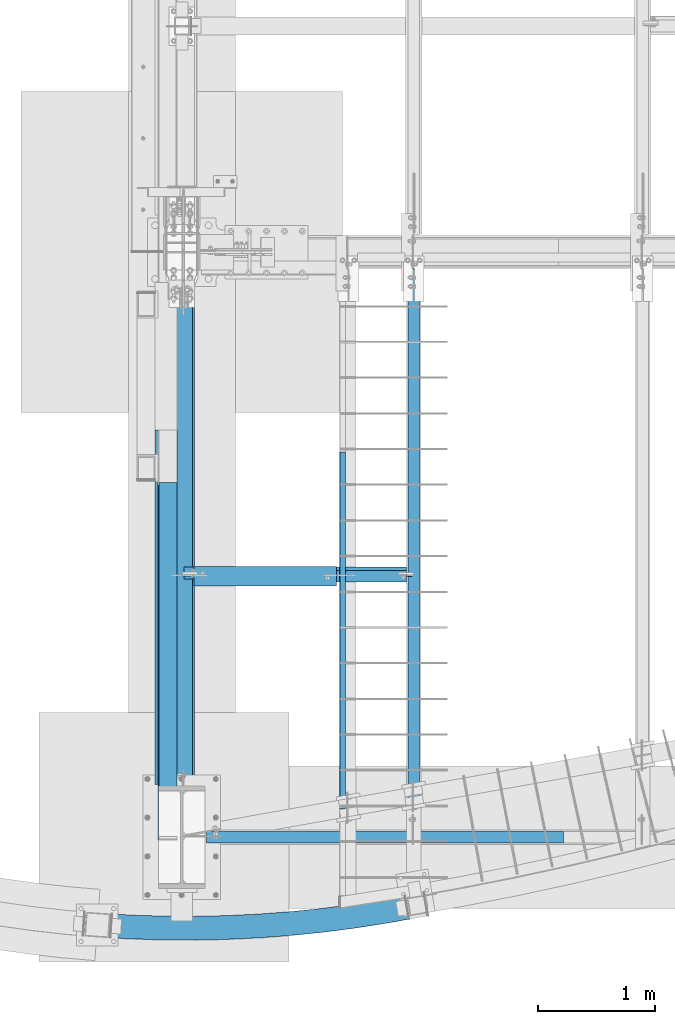
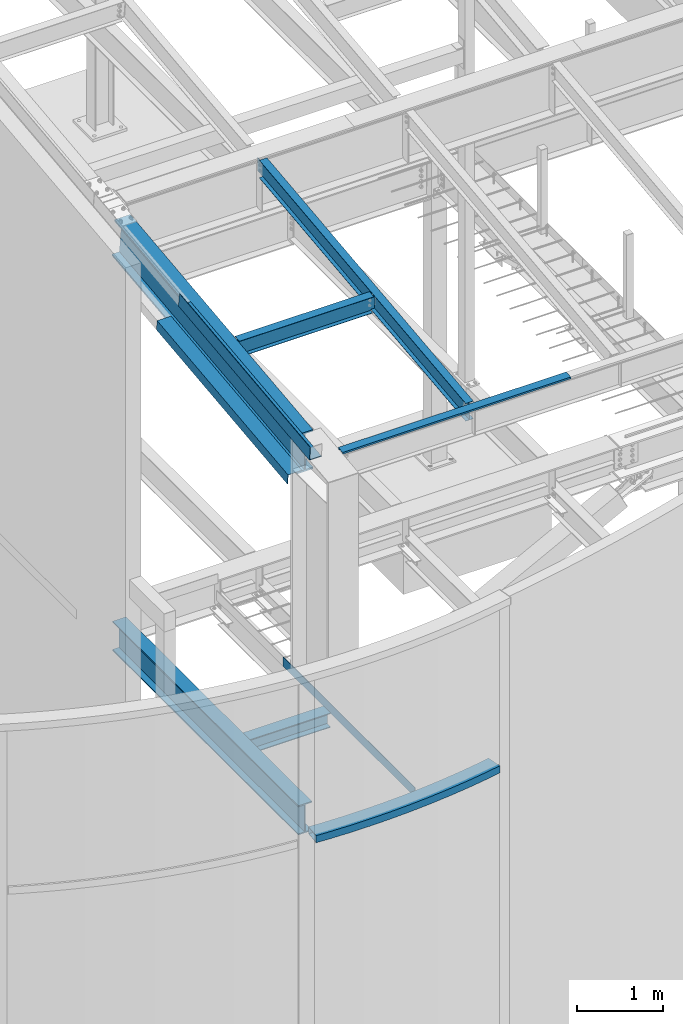
# One storey, part 701 of 1179: 10 beams, 8 elements without a shape of their own.
"""IFC2X3 building model written with IfcOpenShell, lengths in millimetres."""

from ifc_helpers import new_model, si_unit, frame, origin_with_axes, place, context, subcontext, project, spatial, faceted_brep, material, type_object, element, aggregate, save


model = new_model("IFC2X3")

# Units and contexts
model_context = context("Model", 3, precision=1e-05, world=origin_with_axes())
body_context = subcontext(model_context, "Body", "Model", "MODEL_VIEW")
ifc_project = project(units=[si_unit("LENGTHUNIT", "METRE", prefix="MILLI"), si_unit("AREAUNIT", "SQUARE_METRE"), si_unit("VOLUMEUNIT", "CUBIC_METRE"), si_unit("MASSUNIT", "GRAM", prefix="KILO"), si_unit("TIMEUNIT", "SECOND"), si_unit("PLANEANGLEUNIT", "RADIAN"), si_unit("SOLIDANGLEUNIT", "STERADIAN"), si_unit("THERMODYNAMICTEMPERATUREUNIT", "DEGREE_CELSIUS"), si_unit("LUMINOUSINTENSITYUNIT", "LUMEN")], contexts=[model_context])

# Site, building, storey
site_placement = place(None, origin_with_axes())
site = spatial("IfcSite", under=ifc_project, at=site_placement, CompositionType="ELEMENT")
building_placement = place(site_placement, origin_with_axes())
building = spatial("IfcBuilding", under=site, at=building_placement, Name="Undefined", CompositionType="ELEMENT")
storey_placement = place(building_placement, origin_with_axes())
storey = spatial("IfcBuildingStorey", under=building, at=storey_placement, Name="Undefined", CompositionType="ELEMENT", Elevation=0.0)

# Assembly, beam
assembly_1_placement = place(storey_placement, origin_with_axes())
assembly_1 = element("IfcElementAssembly", 1, at=assembly_1_placement, inside=storey, Name="BEAM", AssemblyPlace="NOTDEFINED", PredefinedType="RIGID_FRAME")
ifc_material_1 = material()
beam_type_1 = type_object("IfcBeamType", Name="HSS8X4X1/4", PredefinedType="NOTDEFINED")
beam_1_placement = place(assembly_1_placement, frame((-288.925, -311.15, 4603.7497997099), z_axis=(0.0055405330007161, 0.99998465112924, 0.0), x_axis=(0.99998465112924, -0.00554053300071608, 0.0)))
beam_1 = element("IfcBeam", 2, at=beam_1_placement, type_object=beam_type_1, material=ifc_material_1, Name="BEAM", ObjectType="HSS8X4X1/4", context=body_context, shape_type="Brep", body=[
    faceted_brep([(2445.24095608162, 50.8000000000002, 230.724427011033), (2445.24095608162, -50.8000000000002, 230.724427011033), (2622.91663668657, -50.8000000000002, 264.413853416089), (2622.91663668657, 50.8000000000002, 264.413853416089), (2480.40937850152, -50.8000000000002, 30.5909164124932), (2480.40937850152, 50.8000000000002, 30.5909164124932), (2658.44514956794, 50.8000000000002, 64.3486202602439), (2658.44514956794, -50.8000000000002, 64.3486202602439), (2206.55177206383, 50.8000000000002, -13.7474882341937), (2206.55177206383, -50.8000000000002, -13.7474882341937), (2176.77439599442, -50.8000000000002, 187.258849661955), (2176.77439599442, 50.8000000000002, 187.258849661955), (1907.2367121902, -50.8000000000002, 151.023682920197), (1907.2367121902, 50.8000000000002, 151.023682920197), (1931.60153279603, 50.8000000000002, -50.7102892234303), (1931.60153279603, -50.8000000000002, -50.7102892234303), (1636.82260001464, -50.8000000000002, 122.045100559358), (1636.82260001464, 50.8000000000002, 122.045100559358), (1655.75726569879, 50.8000000000002, -80.2707871890572), (1655.75726569879, -50.8000000000002, -80.2707871890572), (1379.21822155654, 50.8000000000002, -102.407629675677), (1379.21822155654, -50.8000000000002, -102.407629675677), (1365.7273878845, -50.8000000000002, 100.344034699326), (1365.7273878845, 50.8000000000002, 100.344034699326), (1102.18415301249, 50.8000000000002, -117.104826562215), (1102.18415301249, -50.8000000000002, -117.104826562215), (1094.146896196, -50.8000000000002, 85.9361606863359), (1094.146896196, 50.8000000000002, 85.9361606863359), (822.277295877645, -50.8000000000002, 78.8318857702116), (822.277295877645, 50.8000000000002, 78.8318857702116), (824.855170281195, 50.8000000000002, -124.351761612051), (824.855170281195, -50.8000000000002, -124.351761612051), (550.314966690011, -50.8000000000002, 79.0363415868717), (550.314966690011, 50.8000000000002, 79.0363415868717), (547.43159660278, 50.8000000000002, -124.143200141474), (547.43159660278, -50.8000000000002, -124.143200141474), (270.113823543309, 50.8000000000002, -116.47929280083), (270.113823543309, -50.8000000000002, -116.47929280083), (278.456355374569, -50.8000000000002, 86.5493804516062), (278.456355374569, 50.8000000000002, 86.5493804516062), (126.157318260189, -50.8000000000002, 94.8587946466992), (113.106670144839, -50.8000000000002, -107.913004438806), (113.106670144839, 50.8000000000002, -107.913004438806), (126.157318260189, 50.8000000000002, 94.8587946466992), (270.374527663036, 44.4499999999998, -110.134646761691), (547.521701918006, 44.4499999999998, -117.793839462461), (824.774611706084, 44.4499999999998, -118.002272631356), (1101.93298873697, 44.4499999999998, -110.759795710696), (1378.79663300429, 44.4499999999998, -96.0716401639578), (1655.16555739616, 44.4499999999998, -73.9484156969182), (1930.8401321521, 44.4499999999998, -44.4061025939421), (2205.62122906167, 44.4499999999998, -7.46604017493934), (2479.3103653009, 44.4499999999998, 36.8450886186981), (2657.33488354039, 44.4499999999998, 70.6006587963644), (2624.02690271411, 44.4499999999998, 258.161814879968), (2446.33996928224, 44.4499999999998, 224.470254804828), (2177.70493899659, 44.4499999999998, 180.977401602699), (1907.99811283413, 44.4499999999998, 144.719496290707), (1637.41430831727, 44.4499999999998, 115.722729067221), (1366.14897643675, 44.4499999999998, 94.0080451876064), (1094.39806047151, 44.4499999999998, 79.5911298348195), (822.357854452756, 44.4499999999998, 72.482396789516), (550.224861374785, 44.4499999999998, 72.6869809078611), (278.195651254842, 44.4499999999998, 80.2047344124671), (125.749485506584, 44.4499999999998, 88.5221759252769), (113.514502898443, 44.4499999999998, -101.576385717384), (278.195651254842, -44.4499999999998, 80.2047344124671), (125.749485506584, -44.4499999999998, 88.5221759252769), (550.224861374785, -44.4499999999998, 72.6869809078611), (822.357854452756, -44.4499999999998, 72.482396789516), (1094.39806047151, -44.4499999999998, 79.5911298348195), (1366.14897643675, -44.4499999999998, 94.0080451876064), (1637.41430831727, -44.4499999999998, 115.722729067221), (1907.99811283413, -44.4499999999998, 144.719496290707), (2177.70493899659, -44.4499999999998, 180.977401602699), (2446.33996928224, -44.4499999999998, 224.470254804828), (2624.02690271411, -44.4499999999998, 258.161814879968), (2657.33488354039, -44.4499999999998, 70.6006587963644), (2479.3103653009, -44.4499999999998, 36.8450886186981), (2205.62122906167, -44.4499999999998, -7.46604017493934), (1930.8401321521, -44.4499999999998, -44.406102593942), (1655.16555739616, -44.4499999999998, -73.9484156969182), (1378.79663300429, -44.4499999999998, -96.0716401639578), (1101.93298873697, -44.4499999999998, -110.759795710696), (824.774611706085, -44.4499999999998, -118.002272631356), (547.521701918006, -44.4499999999998, -117.793839462461), (270.374527663037, -44.4499999999998, -110.134646761691), (113.514502898443, -44.4499999999998, -101.576385717384)], [[[0, 1, 2, 3]], [[4, 5, 6, 7]], [[8, 5, 4, 9]], [[10, 1, 0, 11]], [[12, 10, 11, 13]], [[14, 8, 9, 15]], [[16, 12, 13, 17]], [[18, 14, 15, 19]], [[20, 18, 19, 21]], [[22, 16, 17, 23]], [[24, 20, 21, 25]], [[26, 22, 23, 27]], [[28, 26, 27, 29]], [[30, 24, 25, 31]], [[32, 28, 29, 33]], [[34, 30, 31, 35]], [[36, 34, 35, 37]], [[38, 32, 33, 39]], [[37, 35, 31, 25, 21, 19, 15, 9, 4, 7, 2, 1, 10, 12, 16, 22, 26, 28, 32, 38, 40, 41]], [[36, 37, 41, 42]], [[39, 33, 29, 27, 23, 17, 13, 11, 0, 3, 6, 5, 8, 14, 18, 20, 24, 30, 34, 36, 42, 43]], [[38, 39, 43, 40]], [[44, 45, 46, 47, 48, 49, 50, 51, 52, 53, 54, 55, 56, 57, 58, 59, 60, 61, 62, 63, 64, 65]], [[63, 66, 67, 64]], [[66, 68, 69, 70, 71, 72, 73, 74, 75, 76, 77, 78, 79, 80, 81, 82, 83, 84, 85, 86, 87, 67]], [[42, 41, 40, 43], [65, 64, 67, 87]], [[86, 44, 65, 87]], [[86, 85, 45, 44]], [[63, 62, 68, 66]], [[85, 84, 46, 45]], [[62, 61, 69, 68]], [[61, 60, 70, 69]], [[84, 83, 47, 46]], [[60, 59, 71, 70]], [[83, 82, 48, 47]], [[82, 81, 49, 48]], [[59, 58, 72, 71]], [[81, 80, 50, 49]], [[58, 57, 73, 72]], [[57, 56, 74, 73]], [[80, 79, 51, 50]], [[56, 55, 75, 74]], [[79, 78, 52, 51]], [[52, 78, 77, 53]], [[75, 55, 54, 76]], [[3, 2, 7, 6], [54, 53, 77, 76]]]),
])
aggregate(assembly_1, [beam_1])

assembly_2_placement = place(storey_placement, origin_with_axes())
assembly_2 = element("IfcElementAssembly", 3, at=assembly_2_placement, inside=storey, Name="BEAM", AssemblyPlace="NOTDEFINED", PredefinedType="RIGID_FRAME")
ifc_material_2 = material(Name="STEEL/A36")
beam_type_2 = type_object("IfcBeamType", PredefinedType="NOTDEFINED")
beam_2_placement = place(assembly_2_placement, frame((1828.8, 2203.36274519487, 3851.275), z_axis=(0.0, -1.0, 0.0), x_axis=(-1.0, 0.0, 0.0)))
beam_2 = element("IfcBeam", 4, at=beam_2_placement, type_object=beam_type_2, material=ifc_material_2, Name="BENT_PLATE", context=body_context, shape_type="Brep", body=[
    faceted_brep([(0.0, -3.17499999999927, -1524.0), (6.00266503170133e-10, -3.17499999922438, 1524.00000000052), (6.00266503170133e-10, 3.17500000077416, 1524.00000000052), (0.0, 3.17499999999927, -1524.0), (50.8000003793823, 3.17500000000018, 1524.00000000025), (50.8000003652887, 3.17500000000018, -1524.0000000005), (44.4500003652829, -3.17500000000018, -1524.00000000048), (44.4500003793801, -3.17500000000018, 1524.00000000027), (50.8000003777524, -130.175006110244, 1524.00000000011), (50.8000003669185, -130.175006107039, -1524.00000000063), (44.4500003777466, -130.175006110244, 1524.00000000013), (44.4500003669127, -130.175006107039, -1524.00000000062)], [[[0, 1, 2, 3]], [[3, 2, 4, 5]], [[1, 0, 6, 7]], [[5, 4, 8, 9]], [[4, 2, 1, 7, 10, 8]], [[7, 6, 11, 10]], [[6, 0, 3, 5, 9, 11]], [[10, 11, 9, 8]]]),
])
aggregate(assembly_2, [beam_2])

assembly_3_placement = place(storey_placement, origin_with_axes())
assembly_3 = element("IfcElementAssembly", 5, at=assembly_3_placement, inside=storey, Name="BEAM", AssemblyPlace="NOTDEFINED", PredefinedType="RIGID_FRAME")
ifc_material_3 = material(Name="STEEL/A992")
beam_type_3 = type_object("IfcBeamType", Name="W10X12", PredefinedType="NOTDEFINED")
beam_3_placement = place(assembly_3_placement, frame((431.800000000003, 2681.08182794842, 9423.63344717243), z_axis=(0.0, -0.112284087038017, 0.993676146336441), x_axis=(1.0, 0.0, 0.0)))
beam_3 = element("IfcBeam", 6, at=beam_3_placement, type_object=beam_type_3, material=ifc_material_3, Name="BEAM", ObjectType="W10X12", context=body_context, shape_type="Brep", body=[
    faceted_brep([(1917.7, -2.38124999999445, -120.649999999938), (1917.7, -50.7999999999893, -120.649999999914), (1917.7, -50.7999999999888, -125.412499999911), (1917.7, 50.8000000000006, -125.412499999957), (1917.7, 50.7999999999997, -120.64999999996), (1917.7, 2.38125000000537, -120.649999999938), (1917.7, 2.38125000000537, -115.887499807657), (1917.7, -2.38124999999445, -115.887499807654), (1918.66672992258, 2.38125000000446, -111.027420289622), (1918.66672992258, -2.38124999999491, -111.027420289614), (1921.41974382306, 2.38125000000446, -106.907243821472), (1921.41974382306, -2.38124999999445, -106.907243821468), (1925.53992029122, 2.38125000000446, -104.154229921), (1925.53992029122, -2.38124999999491, -104.154229920996), (1930.39999980926, 2.38125000000446, -103.187499998412), (1930.39999980926, -2.38124999999491, -103.187499998407), (1966.9125, -2.38124999999536, -103.187499998352), (1966.9125, 2.38125000000446, -103.187499998352), (119.062499999999, 2.38124999999354, 120.64999999994), (119.062499999999, 50.7999999999888, 120.649999999916), (1833.56275, 50.7999999999888, 120.649999999916), (1917.7, 50.7999999999888, 120.649999999916), (1917.7, 2.38124999999354, 120.64999999994), (20.6374999999986, 2.38125000000537, -120.649999999938), (20.6374999999986, 50.7999999999997, -120.64999999996), (20.6374999999986, 50.8000000000006, -125.412499999957), (20.6374999999986, -50.7999999999888, -125.412499999911), (20.6374999999986, -50.7999999999893, -120.649999999914), (20.6374999999986, -2.38124999999445, -120.649999999938), (20.6374999999986, -2.381250000004, 87.3125000025811), (20.6374999999986, 2.38124999999536, 87.312500002583), (106.362500190734, -2.38125000000446, 87.3125000026412), (106.362500190734, 2.38124999999536, 87.3125000026375), (111.222579708779, -2.381250000004, 88.2792299252287), (111.222579708779, 2.38124999999536, 88.2792299252233), (115.342756176933, -2.381250000004, 91.0322438257008), (115.342756176933, 2.38124999999536, 91.0322438256972), (118.095770077411, -2.38125000000446, 95.1524202938508), (118.095770077411, 2.38124999999536, 95.1524202938454), (119.062499999999, -2.38125000000446, 100.012499811888), (119.062499999999, 2.38124999999491, 100.012499811884), (119.062499999999, -50.8000000000006, 125.41249999996), (119.062499999999, 50.7999999999888, 125.412499999913), (119.062499999999, -2.38125000000537, 120.64999999994), (119.062499999999, -50.8000000000002, 120.649999999963), (1917.7, -2.38125000000537, 120.64999999994), (1917.7, -50.8000000000002, 120.649999999963), (1917.7, -50.8000000000006, 125.41249999996), (1917.7, 50.7999999999888, 125.412499999913), (1917.7, -2.38125000000537, 115.887499810537), (1917.7, 2.381249999994, 115.887499810531), (1918.66672992258, -2.38125000000537, 111.027420292497), (1918.66672992258, 2.38124999999445, 111.027420292494), (1921.41974382306, -2.38125000000491, 106.907243824351), (1921.41974382306, 2.38124999999445, 106.907243824346), (1925.53992029122, -2.38125000000446, 104.154229923875), (1925.53992029122, 2.38124999999445, 104.154229923872), (1930.39999980926, -2.38125000000446, 103.187500001291), (1930.39999980926, 2.38124999999445, 103.187500001286), (1966.9125, -2.38125000000446, 103.187500001346), (1966.9125, 2.38124999999445, 103.187500001348)], [[[0, 1, 2, 3, 4, 5, 6, 7]], [[7, 6, 8, 9]], [[9, 8, 10, 11]], [[11, 10, 12, 13]], [[13, 12, 14, 15]], [[16, 15, 14, 17]], [[18, 19, 20, 21, 22]], [[23, 24, 25, 26, 27, 28, 29, 30]], [[31, 32, 30, 29]], [[33, 34, 32, 31]], [[35, 36, 34, 33]], [[37, 38, 36, 35]], [[39, 40, 38, 37]], [[41, 42, 19, 18, 40, 39, 43, 44]], [[44, 43, 45, 46]], [[41, 44, 46, 47]], [[42, 41, 47, 48]], [[20, 19, 42, 48, 21]], [[47, 46, 45, 49, 50, 22, 21, 48]], [[51, 52, 50, 49]], [[53, 54, 52, 51]], [[55, 56, 54, 53]], [[57, 58, 56, 55]], [[59, 60, 58, 57]], [[60, 59, 16, 17]], [[12, 10, 8, 6, 5, 23, 30, 32, 34, 36, 38, 40, 18, 22, 50, 52, 54, 56, 58, 60, 17, 14]], [[24, 23, 5, 4]], [[25, 24, 4, 3]], [[26, 25, 3, 2]], [[27, 26, 2, 1]], [[28, 27, 1, 0]], [[59, 57, 55, 53, 51, 49, 45, 43, 39, 37, 35, 33, 31, 29, 28, 0, 7, 9, 11, 13, 15, 16]]]),
])
aggregate(assembly_3, [beam_3])

assembly_4_placement = place(storey_placement, origin_with_axes())
assembly_4 = element("IfcElementAssembly", 7, at=assembly_4_placement, inside=storey, Name="BEAM", AssemblyPlace="NOTDEFINED", PredefinedType="RIGID_FRAME")
beam_4_placement = place(assembly_4_placement, frame((2413.0, 452.231593993459, 9171.78056384809), z_axis=(-3.89779463887408e-08, -0.112282221021699, 0.993676357192035), x_axis=(0.0, 0.993676357192036, 0.112282221021699)))
beam_4 = element("IfcBeam", 8, at=beam_4_placement, type_object=beam_type_3, material=ifc_material_3, Name="BEAM", ObjectType="W10X12", context=body_context, shape_type="Brep", body=[
    faceted_brep([(4857.69134886906, 2.38125000000036, -120.649999999367), (4857.69134886908, 2.38119321150953, -125.412499999362), (4857.69133715173, 50.7999999999993, -125.412499999366), (4857.69133715173, 50.7999999999993, -120.649999999367), (4982.24975567706, 2.38124999999991, -120.649999999352), (4981.71160854873, 2.3812232242517, -125.412499999349), (48.8806597554974, -2.38124999999854, -120.649999999914), (48.8806597554974, -50.7999999999993, -120.649999999914), (4857.69136171279, -50.7999999999993, -120.649999999368), (4857.69134999544, -2.38125000000036, -120.649999999367), (76.1467808989316, 2.38124999999854, 120.649999999929), (76.1467808989316, 50.7999999999993, 120.649999999929), (4881.74500230402, 50.7999999999993, 120.650000000474), (4881.74500230402, 2.38125000000036, 120.650000000474), (48.3425126276663, -50.7999999999993, -125.412499999911), (76.1467808989316, -2.38124999999854, 120.649999999929), (76.1467808989316, -50.7999999999993, 120.649999999929), (76.6849280267622, -50.7999999999993, 125.412499999924), (76.6849280267622, 50.7999999999993, 125.412499999924), (48.8806597554974, 2.38124999999854, -120.649999999914), (48.8806597554974, 50.7999999999993, -120.649999999914), (48.3425126276663, 50.7999999999993, -125.412499999911), (4857.69136171279, -50.7999999999993, -125.412499999366), (4857.69134999547, -2.38130675233151, -125.412499999364), (4982.24966581192, -2.38124999999991, -120.649999999354), (4981.71151868358, -2.38127673905228, -125.412499999351), (4884.49824407442, -2.38125000000036, 75.1923220895023), (4880.7132366458, -2.38125000000036, 78.3905494782684), (4878.44025438672, -2.38125000000036, 82.793785937376), (4878.02533824148, -2.38125000000036, 87.7316786313622), (4881.74500230402, -2.38125000000036, 120.650000000474), (4982.33569543271, -2.38124999999991, -119.888654174283), (5002.7592944571, -2.38124999999991, 60.8563230322561), (4889.21904360274, -2.38125000000036, 73.6860048990093), (4881.74500230402, -50.7999999999993, 120.650000000474), (4882.28314943185, -50.7999999999993, 125.41250000047), (4882.28314943185, 50.7999999999993, 125.41250000047), (4878.02533824148, 2.38125000000036, 87.7316786313622), (4878.44025438672, 2.38125000000036, 82.793785937376), (4880.7132366458, 2.38125000000036, 78.3905494782684), (4884.49824407442, 2.38125000000036, 75.1923220895023), (4889.21904360274, 2.38125000000036, 73.6860048990093), (5002.75938318929, 2.38124999999991, 60.8563130058046), (4982.33577246425, 2.38124999999991, -119.888767749349)], [[[0, 1, 2, 3]], [[4, 5, 1, 0]], [[6, 7, 8, 9]], [[10, 11, 12, 13]], [[14, 7, 6, 15, 16, 17, 18, 11, 10, 19, 20, 21]], [[7, 14, 22, 8]], [[8, 22, 23, 9]], [[24, 9, 23, 25]], [[26, 27, 28, 29, 30, 15, 6, 9, 24, 31, 32, 33]], [[16, 15, 30, 34]], [[17, 16, 34, 35]], [[18, 17, 35, 36]], [[11, 18, 36, 12]], [[35, 34, 30, 29, 37, 13, 12, 36]], [[28, 38, 37, 29]], [[27, 39, 38, 28]], [[26, 40, 39, 27]], [[33, 41, 40, 26]], [[32, 42, 41, 33]], [[43, 4, 0, 19, 10, 13, 37, 38, 39, 40, 41, 42]], [[20, 19, 0, 3]], [[21, 20, 3, 2]], [[25, 23, 22, 14, 21, 2, 1, 5]], [[43, 42, 32, 31, 24, 25, 5, 4]]]),
])
aggregate(assembly_4, [beam_4])

# Assembly, beams
assembly_5_placement = place(storey_placement, origin_with_axes())
assembly_5 = element("IfcElementAssembly", 9, at=assembly_5_placement, inside=storey, Name="BEAM", AssemblyPlace="NOTDEFINED", PredefinedType="RIGID_FRAME")
beam_type_4 = type_object("IfcBeamType", PredefinedType="NOTDEFINED")
beam_5_placement = place(assembly_5_placement, frame((388.937000000002, 1952.15627219168, 9470.67302832209), z_axis=(0.0, -0.993676357192036, -0.112282221021698), x_axis=(-1.0, 0.0, 0.0)))
beam_5 = element("IfcBeam", 10, at=beam_5_placement, type_object=beam_type_4, material=ifc_material_2, Name="BENT_PLATE", context=body_context, shape_type="Brep", body=[
    faceted_brep([(0.0, -3.17499999999927, -1524.0), (6.00266503170133e-10, -3.17499999922438, 1524.00000000052), (6.00266503170133e-10, 3.17500000077416, 1524.00000000052), (0.0, 3.17499999999927, -1524.0), (160.336999999976, 3.174999999379, 1523.99999999915), (160.33700000004, 3.17500000061409, -1523.99999999915), (153.98700000004, -3.17499999938263, -1523.99999999915), (153.986999999976, -3.17500000061773, 1523.99999999914), (160.337000000008, -187.325000000099, 1523.99999999907), (160.337000000008, -187.324999998866, -1523.99999999923), (153.987000000008, -187.325000000099, 1523.99999999907), (153.987000000008, -187.324999998866, -1523.99999999923)], [[[0, 1, 2, 3]], [[3, 2, 4, 5]], [[1, 0, 6, 7]], [[5, 4, 8, 9]], [[4, 2, 1, 7, 10, 8]], [[7, 6, 11, 10]], [[6, 0, 3, 5, 9, 11]], [[10, 11, 9, 8]]]),
])
beam_type_5 = type_object("IfcBeamType", PredefinedType="NOTDEFINED")
beam_6_placement = place(assembly_5_placement, frame((388.937000203005, 2403.71894899032, 8992.89453938418), z_axis=(0.0, -0.993676146336441, -0.112284087038017), x_axis=(-1.0, 0.0, 0.0)))
beam_6 = element("IfcBeam", 11, at=beam_6_placement, type_object=beam_type_5, material=ifc_material_2, Name="BENT_PLATE", context=body_context, shape_type="Brep", body=[
    faceted_brep([(0.0, -3.17499999999927, -1524.0), (6.00266503170133e-10, -3.17499999922438, 1524.00000000052), (6.00266503170133e-10, 3.17500000077416, 1524.00000000052), (0.0, 3.17499999999927, -1524.0), (179.387000203274, 3.1749999978274, 1523.9999999998), (179.387000201926, 3.17499999921893, -1523.99999999987), (185.737000201926, -3.17500000083055, -1523.99999999987), (185.737000203274, -3.17500000222026, 1523.9999999998), (179.387000202948, 136.524999792875, 1523.99999999976), (179.387000202255, 136.524999793486, -1523.99999999991), (185.737000202948, 136.524999792873, 1523.99999999976), (185.737000202255, 136.524999793486, -1523.99999999991)], [[[0, 1, 2, 3]], [[3, 2, 4, 5]], [[1, 0, 6, 7]], [[5, 4, 8, 9]], [[4, 2, 1, 7, 10, 8]], [[7, 6, 11, 10]], [[6, 0, 3, 5, 9, 11]], [[10, 11, 9, 8]]]),
])

# Assembly, beam
assembly_6_placement = place(storey_placement, origin_with_axes())
assembly_6 = element("IfcElementAssembly", 12, at=assembly_6_placement, inside=storey, Name="BEAM", AssemblyPlace="NOTDEFINED", PredefinedType="RIGID_FRAME")
beam_type_6 = type_object("IfcBeamType", PredefinedType="NOTDEFINED")
beam_7_placement = place(assembly_6_placement, frame((2168.52499999974, 485.77499911942, 9265.24531303941), z_axis=(-1.0, 0.0, 0.0), x_axis=(0.0, 0.0, 1.0)))
beam_7 = element("IfcBeam", 13, at=beam_7_placement, type_object=beam_type_6, material=ifc_material_2, Name="BENT_PLATE", context=body_context, shape_type="Brep", body=[
    faceted_brep([(0.0, -3.17499999999927, -1524.0), (6.00266503170133e-10, -3.17499999922438, 1524.00000000052), (6.00266503170133e-10, 3.17500000077416, 1524.00000000052), (0.0, 3.17499999999927, -1524.0), (36.8806648358295, 3.17499999974928, 1524.0), (36.8806648358295, 3.17499999974928, -1524.0), (29.7727112184712, -3.17500000020243, -1524.0), (29.7727112184712, -3.17500000020243, 1524.0), (25.3999996289767, -98.4249984738682, 1524.0), (25.3999996289767, -98.4249984738682, -1524.0), (19.7271291840298, -92.0749984738682, -1524.0), (19.7271291840298, -92.0749984738682, 1524.0), (2.13476596400142e-08, -98.4249984738682, 1524.0), (2.13476596400142e-08, -98.4249984738682, -1524.0), (2.13476596400142e-08, -92.0749984738682, 1524.0), (2.13476596400142e-08, -92.0749984738682, -1524.0)], [[[0, 1, 2, 3]], [[3, 2, 4, 5]], [[1, 0, 6, 7]], [[5, 4, 8, 9]], [[7, 6, 10, 11]], [[9, 8, 12, 13]], [[8, 4, 2, 1, 7, 11, 14, 12]], [[11, 10, 15, 14]], [[10, 6, 0, 3, 5, 9, 13, 15]], [[14, 15, 13, 12]]]),
])
aggregate(assembly_6, [beam_7])

assembly_7_placement = place(storey_placement, origin_with_axes())
assembly_7 = element("IfcElementAssembly", 14, at=assembly_7_placement, inside=storey, Name="BEAM", AssemblyPlace="NOTDEFINED", PredefinedType="RIGID_FRAME")
beam_type_7 = type_object("IfcBeamType", Name="W16X57", PredefinedType="NOTDEFINED")
beam_8_placement = place(assembly_7_placement, frame((431.800000000002, 438.15, 3894.1375), z_axis=(0.0, 0.0, 1.0), x_axis=(0.0, 1.0, 0.0)))
beam_8 = element("IfcBeam", 15, at=beam_8_placement, type_object=beam_type_7, material=ifc_material_3, Name="BEAM", ObjectType="W16X57", context=body_context, shape_type="Brep", body=[
    faceted_brep([(450.85, -90.4875, -207.9625), (450.85, 90.4875, -207.9625), (4750.59739418356, 90.4875, -207.9625), (4750.59739418356, -90.4875, -207.9625), (450.85, -90.4875, -190.5), (450.85, -5.55624999999998, -190.5), (450.85, -5.55624999999998, 190.5), (450.85, -90.4875, 190.5), (450.85, -90.4875, 207.9625), (450.85, 90.4875, 207.9625), (450.85, 90.4875, 190.5), (450.85, 5.55624999999998, 190.5), (450.85, 5.55624999999998, -190.5), (450.85, 90.4875, -190.5), (4750.59741014429, -90.4875, -190.5), (4750.59741014429, -5.55624999999998, -190.5), (4750.59744864425, -5.55624999999998, -148.377500106371), (4750.59772858417, -5.55624999999998, 157.90249989339), (4750.59775837829, -5.55624999999998, 190.5), (4750.59775837829, -90.4875, 190.5), (4750.59777433901, -90.4875, 207.9625), (4750.59777433901, 90.4875, 207.9625), (4750.59775837829, 90.4875, 190.5), (4750.59775837829, 5.55624999999998, 190.5), (4750.59741014429, 5.55624999999998, -190.5), (4750.59741014429, 90.4875, -190.5)], [[[0, 1, 2, 3]], [[0, 4, 5, 6, 7, 8, 9, 10, 11, 12, 13, 1]], [[5, 4, 14, 15]], [[6, 5, 15, 16, 17, 18]], [[7, 6, 18, 19]], [[8, 7, 19, 20]], [[9, 8, 20, 21]], [[10, 9, 21, 22]], [[11, 10, 22, 23]], [[12, 11, 23, 24]], [[13, 12, 24, 25]], [[1, 13, 25, 2]], [[24, 23, 22, 21, 20, 19, 18, 17, 16, 15, 14, 3, 2, 25]], [[4, 0, 3, 14]]]),
])
aggregate(assembly_7, [beam_8])

# Beam
beam_type_8 = type_object("IfcBeamType", Name="W21X93", PredefinedType="NOTDEFINED")
beam_9_placement = place(assembly_5_placement, frame((431.800000000001, 468.986908358538, 9023.49921050194), z_axis=(-3.89779463887408e-08, -0.112282221021699, 0.993676357192035), x_axis=(0.0, 0.993676357192036, 0.112282221021699)))
beam_9 = element("IfcBeam", 16, at=beam_9_placement, type_object=beam_type_8, material=ifc_material_3, Name="BEAM", ObjectType="W21X93", context=body_context, shape_type="Brep", body=[
    faceted_brep([(391.652856100045, -106.362499999999, -274.63749999977), (391.652856100045, 106.362499999999, -274.63749999977), (4708.38412887017, 106.3625, -274.63749999928), (4708.38412887017, -106.3625, -274.63749999928), (394.3435917392, -106.362499999999, -250.824999999786), (394.3435917392, -7.14374999999927, -250.824999999786), (404.479337592957, -7.14375000000001, -161.125570353071), (447.483428244283, -7.14375000000001, 219.452474450971), (451.028422537392, -7.14374999999927, 250.824999999882), (451.028422537392, -106.362499999999, 250.824999999882), (453.719158176547, -106.362499999999, 274.637499999868), (453.719158176547, 106.362499999999, 274.637499999868), (451.028422537392, 106.362499999999, 250.824999999882), (451.028422537392, 7.14374999999927, 250.824999999882), (394.3435917392, 7.14374999999927, -250.824999999786), (394.3435917392, 106.362499999999, -250.824999999786), (4708.38412887017, -106.3625, -250.824999999299), (4708.38412887017, -7.14375000000001, -250.824999999299), (4708.38412887019, -7.14375000000001, 250.825000000366), (4708.38412887019, -106.3625, 250.825000000366), (4708.38412887019, -106.3625, 274.63750000035), (4708.38412887019, 106.3625, 274.63750000035), (4708.38412887019, 106.3625, 250.825000000366), (4708.38412887019, 7.14375000000001, 250.825000000366), (4708.38412887019, 7.14375000000001, 200.40927085678), (4708.38412887017, 7.14375000000001, -199.807098320998), (4708.38412887017, 7.14375000000001, -250.824999999299), (4708.38412887017, 106.3625, -250.824999999299)], [[[0, 1, 2, 3]], [[0, 4, 5, 6, 7, 8, 9, 10, 11, 12, 13, 14, 15, 1]], [[5, 4, 16, 17]], [[8, 7, 6, 5, 17, 18]], [[9, 8, 18, 19]], [[10, 9, 19, 20]], [[11, 10, 20, 21]], [[12, 11, 21, 22]], [[13, 12, 22, 23]], [[14, 13, 23, 24, 25, 26]], [[15, 14, 26, 27]], [[1, 15, 27, 2]], [[26, 25, 24, 23, 22, 21, 20, 19, 18, 17, 16, 3, 2, 27]], [[4, 0, 3, 16]]]),
])

aggregate(assembly_5, [beam_6, beam_5, beam_9])

# Assembly, beam
assembly_8_placement = place(storey_placement, origin_with_axes())
assembly_8 = element("IfcElementAssembly", 17, at=assembly_8_placement, inside=storey, Name="BEAM", AssemblyPlace="NOTDEFINED", PredefinedType="RIGID_FRAME")
beam_type_9 = type_object("IfcBeamType", Name="W8X28", PredefinedType="NOTDEFINED")
beam_10_placement = place(assembly_8_placement, frame((431.800000000002, 2667.0, 3787.775), z_axis=(0.0, 0.0, 1.0), x_axis=(1.0, 0.0, 0.0)))
beam_10 = element("IfcBeam", 18, at=beam_10_placement, type_object=beam_type_9, material=ifc_material_3, Name="BEAM", ObjectType="W8X28", context=body_context, shape_type="Brep", body=[
    faceted_brep([(103.1875, -82.5500000000002, -101.6), (103.1875, 82.5500000000002, -101.6), (1320.8, 82.5500000000002, -101.6), (1320.8, -82.5500000000002, -101.6), (103.1875, -82.5500000000002, -90.4875000000002), (103.1875, -3.96875, -90.4875000000002), (103.1875, -3.96875, 90.4875000000002), (103.1875, -82.5500000000002, 90.4875000000002), (103.1875, -82.5500000000002, 101.6), (103.1875, 82.5500000000002, 101.6), (103.1875, 82.5500000000002, 90.4875000000002), (103.1875, 3.96875, 90.4875000000002), (103.1875, 3.96875, 76.9399980221988), (103.1875, 3.96875, -76.9400093837025), (103.1875, 3.96875, -90.4875000000002), (103.1875, 82.5500000000002, -90.4875000000002), (1320.8, -82.5500000000002, -90.4875000000002), (1320.8, -3.96875, -90.4875000000002), (1320.8, -3.96875, 90.4875000000002), (1320.8, -82.5500000000002, 90.4875000000002), (1320.8, -82.5500000000002, 101.6), (1320.8, 82.5500000000002, 101.6), (1320.8, 82.5500000000002, 90.4875000000002), (1320.8, 3.96875, 90.4875000000002), (1320.8, 3.96875, 76.9400059022819), (1320.8, 3.96875, -76.9400068984164), (1320.8, 3.96875, -90.4875000000002), (1320.8, 82.5500000000002, -90.4875000000002)], [[[0, 1, 2, 3]], [[0, 4, 5, 6, 7, 8, 9, 10, 11, 12, 13, 14, 15, 1]], [[5, 4, 16, 17]], [[6, 5, 17, 18]], [[7, 6, 18, 19]], [[8, 7, 19, 20]], [[9, 8, 20, 21]], [[10, 9, 21, 22]], [[11, 10, 22, 23]], [[14, 13, 12, 11, 23, 24, 25, 26]], [[15, 14, 26, 27]], [[1, 15, 27, 2]], [[26, 25, 24, 23, 22, 21, 20, 19, 18, 17, 16, 3, 2, 27]], [[4, 0, 3, 16]]]),
])
aggregate(assembly_8, [beam_10])

save(model, "model.ifc")
